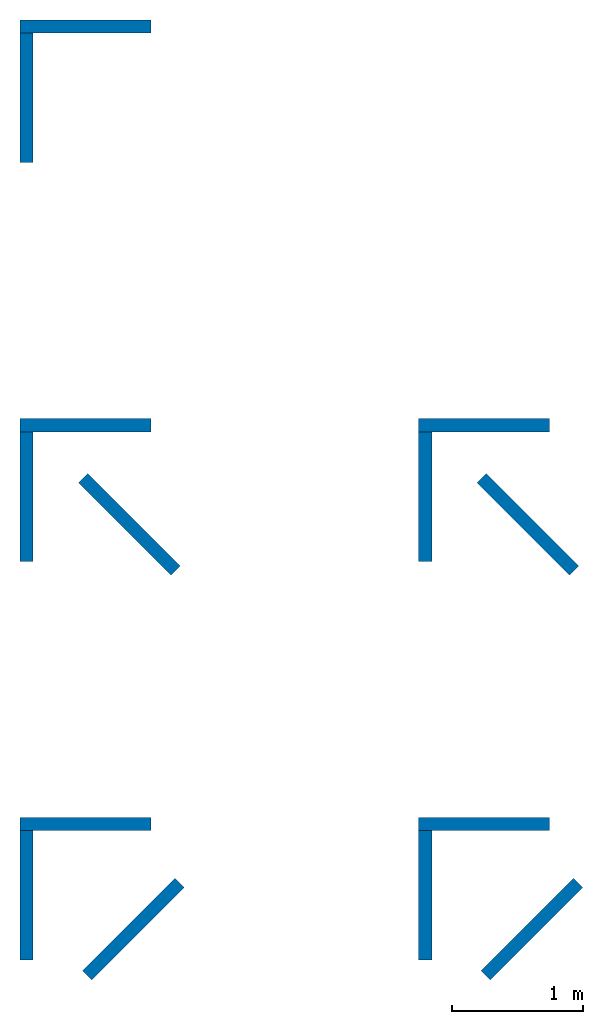
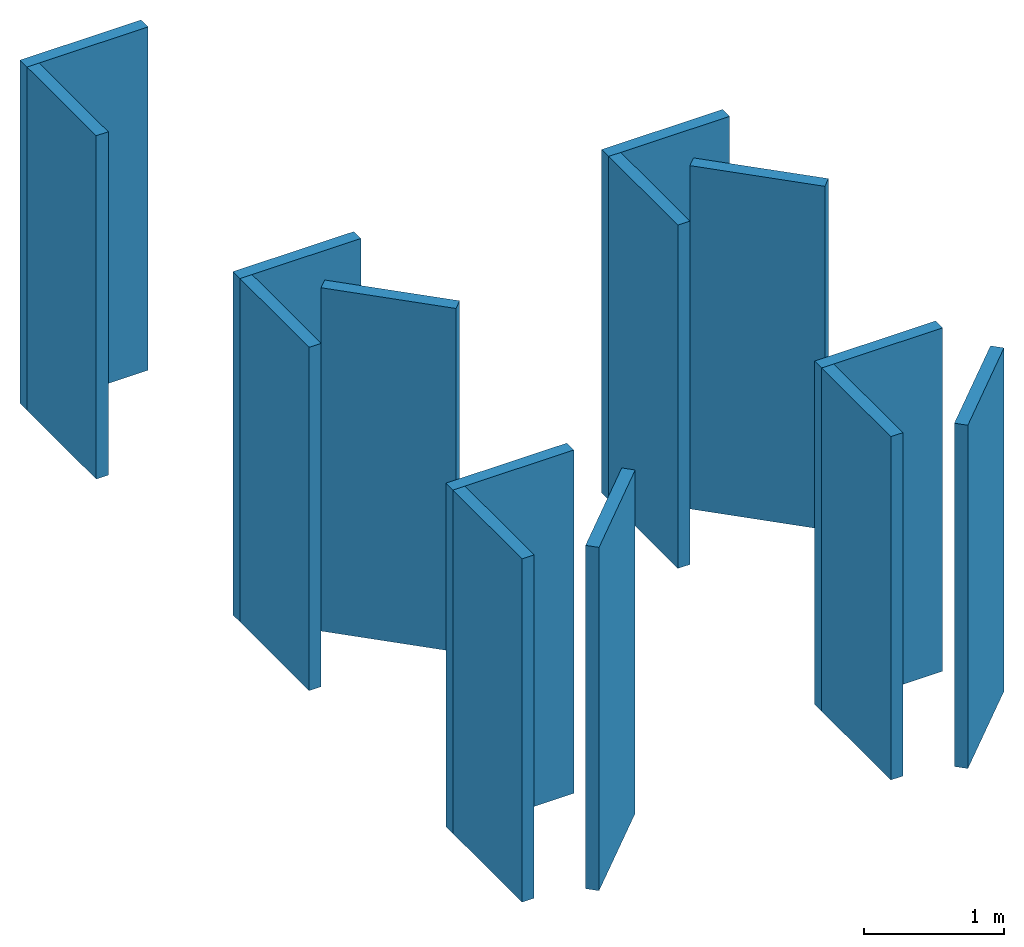
# One storey: 14 walls, 9 elements without a shape of their own.
"""IFC4 building model written with IfcOpenShell, lengths in feet."""

from ifc_helpers import new_model, entity, si_unit, converted_unit, frame, origin_with_axes, origin_2d_with_axis, place, context, subcontext, project, spatial, indexed_curve, outline, extrude, material, layer, layer_set, layer_usage, type_object, element, aggregate, save


model = new_model("IFC4")

# Units and contexts
model_context = context("Model", 3, precision=1e-05, world=origin_with_axes())
plan_context = context("Plan", 2, precision=1e-05, world=origin_2d_with_axis())
body_context = subcontext(model_context, "Body", "Model", "MODEL_VIEW")
ifc_project = project(units=[converted_unit("PLANEANGLEUNIT", "degree", entity("IfcReal", 0.0174532925199433), si_unit("PLANEANGLEUNIT", "RADIAN"), dimensions=[0, 0, 0, 0, 0, 0, 0]), converted_unit("AREAUNIT", "square foot", entity("IfcReal", 0.09290304), si_unit("AREAUNIT", "SQUARE_METRE"), dimensions=[2, 0, 0, 0, 0, 0, 0]), converted_unit("LENGTHUNIT", "foot", entity("IfcReal", 0.3048), si_unit("LENGTHUNIT", "METRE"), dimensions=[1, 0, 0, 0, 0, 0, 0]), converted_unit("VOLUMEUNIT", "cubic foot", entity("IfcReal", 0.0283168467116885), si_unit("VOLUMEUNIT", "CUBIC_METRE"), dimensions=[3, 0, 0, 0, 0, 0, 0])], contexts=[model_context, plan_context])

# Site, building, storey
site_placement = place(None, origin_with_axes())
site = spatial("IfcSite", under=ifc_project, at=site_placement)
building_placement = place(site_placement, origin_with_axes())
building = spatial("IfcBuilding", under=site, at=building_placement, Name="Building")
storey_placement = place(building_placement, origin_with_axes())
storey = spatial("IfcBuildingStorey", under=building, at=storey_placement, Name="Storey")

# Assembly, walls
assembly_1_placement = place(storey_placement, origin_with_axes())
assembly_1 = element("IfcElementAssembly", 1, at=assembly_1_placement, inside=storey, Name="A")
ifc_material = material()
ifc_layer = layer(ifc_material, 0.328083989501312)
ifc_layer_set = layer_set([ifc_layer])
ifc_layer_usage_1 = layer_usage(ifc_layer_set, "AXIS2", "POSITIVE", 0.0)
wall_type = type_object("IfcWallType", Name="WAL100", PredefinedType="NOTDEFINED", material=ifc_layer_set)
wall_1_placement = place(assembly_1_placement, origin_with_axes())
wall_1 = element("IfcWall", 2, at=wall_1_placement, type_object=wall_type, material=ifc_layer_usage_1, Name="Wall", context=body_context, shape_type="SweptSolid", body=[
    extrude(outline(indexed_curve([(0.0, 0.0), (0.0, 0.328083989501312), (3.28083989501312, 0.328083989501312), (3.28083989501312, 0.0), (0.0, 0.0)], self_intersect=False)), origin_with_axes(), (0.0, 0.0, 1.0), 9.84251968503937),
])
ifc_layer_usage_2 = layer_usage(ifc_layer_set, "AXIS2", "POSITIVE", 0.0)
wall_2_placement = place(assembly_1_placement, frame((0.0, 0.0, 0.0), z_axis=(0.0, 0.0, 1.0), x_axis=(-4.37113882867379e-08, -0.999999999999999, 0.0)))
wall_2 = element("IfcWall", 3, at=wall_2_placement, type_object=wall_type, material=ifc_layer_usage_2, Name="Wall", context=body_context, shape_type="SweptSolid", body=[
    extrude(outline(indexed_curve([(0.0, 0.0), (0.0, 0.328083989501312), (3.24999992360233, 0.328083989501312), (3.24999992360233, 0.0), (0.0, 0.0)], self_intersect=False)), origin_with_axes(), (0.0, 0.0, 1.0), 9.84251968503937),
])
aggregate(assembly_1, [wall_1, wall_2])

# Assembly, wall
assembly_2_placement = place(storey_placement, origin_with_axes())
assembly_2 = element("IfcElementAssembly", 4, at=assembly_2_placement, inside=storey, Name="B")
ifc_layer_usage_3 = layer_usage(ifc_layer_set, "AXIS2", "POSITIVE", 0.0)
wall_3_placement = place(assembly_2_placement, frame((1.46177702453819, -11.2787882486979, 0.0), z_axis=(0.0, 0.0, 1.0), x_axis=(0.707106781186548, -0.707106781186548, 0.0)))
wall_3 = element("IfcWall", 5, at=wall_3_placement, type_object=wall_type, material=ifc_layer_usage_3, Name="Wall", context=body_context, shape_type="SweptSolid", body=[
    extrude(outline(indexed_curve([(0.0, 0.0), (0.0, 0.328083989501312), (3.28084067722631, 0.328083989501312), (3.28084067722631, 0.0), (0.0, 0.0)], self_intersect=False)), origin_with_axes(), (0.0, 0.0, 1.0), 9.84251968503937),
])

assembly_3_placement = place(storey_placement, origin_with_axes())
assembly_3 = element("IfcElementAssembly", 6, at=assembly_3_placement, inside=storey, Name="C")
ifc_layer_usage_4 = layer_usage(ifc_layer_set, "AXIS2", "POSITIVE", 0.0)
wall_4_placement = place(assembly_3_placement, frame((1.79947283011409, -23.7494081336995, 0.0), z_axis=(0.0, 0.0, 1.0), x_axis=(0.707106721581899, 0.707106840791191, 0.0)))
wall_4 = element("IfcWall", 7, at=wall_4_placement, type_object=wall_type, material=ifc_layer_usage_4, Name="Wall", context=body_context, shape_type="SweptSolid", body=[
    extrude(outline(indexed_curve([(0.0, 0.0), (0.0, 0.328083989501312), (3.28084067722631, 0.328083989501312), (3.28084067722631, 0.0), (0.0, 0.0)], self_intersect=False)), origin_with_axes(), (0.0, 0.0, 1.0), 9.84251968503937),
])

# Assembly
assembly_4_placement = place(assembly_2_placement, frame((0.0, -10.000000319143, 0.0), z_axis=(0.0, 0.0, 1.0), x_axis=(1.0, 0.0, 0.0)))
assembly_4 = element("IfcElementAssembly", 8, at=assembly_4_placement, Name="A")

aggregate(assembly_2, [assembly_4, wall_3])

# Wall
ifc_layer_usage_5 = layer_usage(ifc_layer_set, "AXIS2", "POSITIVE", 0.0)
wall_5_placement = place(assembly_4_placement, frame((0.0, 2.03977983526932e-14, 0.0), z_axis=(0.0, 0.0, 1.0), x_axis=(3.13916473260163e-07, -0.999999999999951, 0.0)))
wall_5 = element("IfcWall", 9, at=wall_5_placement, type_object=wall_type, material=ifc_layer_usage_5, Name="Wall", context=body_context, shape_type="SweptSolid", body=[
    extrude(outline(indexed_curve([(0.0, 0.0), (0.0, 0.328083989501312), (3.24999992360233, 0.328083989501312), (3.24999992360233, 0.0), (0.0, 0.0)], self_intersect=False)), origin_with_axes(), (0.0, 0.0, 1.0), 9.84251968503937),
])

ifc_layer_usage_6 = layer_usage(ifc_layer_set, "AXIS2", "POSITIVE", 0.0)
wall_6_placement = place(assembly_4_placement, frame((0.0, 2.03977983526932e-14, 0.0), z_axis=(0.0, 0.0, 1.0), x_axis=(1.0, 0.0, 0.0)))
wall_6 = element("IfcWall", 10, at=wall_6_placement, type_object=wall_type, material=ifc_layer_usage_6, Name="Wall", context=body_context, shape_type="SweptSolid", body=[
    extrude(outline(indexed_curve([(0.0, 0.0), (0.0, 0.328083989501312), (3.28083989501312, 0.328083989501312), (3.28083989501312, 0.0), (0.0, 0.0)], self_intersect=False)), origin_with_axes(), (0.0, 0.0, 1.0), 9.84251968503937),
])

aggregate(assembly_4, [wall_5, wall_6])

# Assembly
assembly_5_placement = place(assembly_3_placement, frame((0.0, -20.000000638286, 0.0), z_axis=(0.0, 0.0, 1.0), x_axis=(1.0, 0.0, 0.0)))
assembly_5 = element("IfcElementAssembly", 11, at=assembly_5_placement, Name="A")

aggregate(assembly_3, [assembly_5, wall_4])

# Wall
ifc_layer_usage_7 = layer_usage(ifc_layer_set, "AXIS2", "POSITIVE", 0.0)
wall_7_placement = place(assembly_5_placement, frame((0.0, 4.07955967053863e-14, 0.0), z_axis=(0.0, 0.0, 1.0), x_axis=(3.13916473260163e-07, -0.999999999999951, 0.0)))
wall_7 = element("IfcWall", 12, at=wall_7_placement, type_object=wall_type, material=ifc_layer_usage_7, Name="Wall", context=body_context, shape_type="SweptSolid", body=[
    extrude(outline(indexed_curve([(0.0, 0.0), (0.0, 0.328083989501312), (3.24999992360233, 0.328083989501312), (3.24999992360233, 0.0), (0.0, 0.0)], self_intersect=False)), origin_with_axes(), (0.0, 0.0, 1.0), 9.84251968503937),
])

ifc_layer_usage_8 = layer_usage(ifc_layer_set, "AXIS2", "POSITIVE", 0.0)
wall_8_placement = place(assembly_5_placement, frame((0.0, 4.07955967053863e-14, 0.0), z_axis=(0.0, 0.0, 1.0), x_axis=(1.0, 0.0, 0.0)))
wall_8 = element("IfcWall", 13, at=wall_8_placement, type_object=wall_type, material=ifc_layer_usage_8, Name="Wall", context=body_context, shape_type="SweptSolid", body=[
    extrude(outline(indexed_curve([(0.0, 0.0), (0.0, 0.328083989501312), (3.28083989501312, 0.328083989501312), (3.28083989501312, 0.0), (0.0, 0.0)], self_intersect=False)), origin_with_axes(), (0.0, 0.0, 1.0), 9.84251968503937),
])

aggregate(assembly_5, [wall_7, wall_8])

# Assemblies, walls
assembly_6_placement = place(storey_placement, frame((10.000000319143, 0.0, 0.0), z_axis=(0.0, 0.0, 1.0), x_axis=(1.0, 0.0, 0.0)))
assembly_6 = element("IfcElementAssembly", 14, at=assembly_6_placement, inside=storey, Name="B")
ifc_layer_usage_9 = layer_usage(ifc_layer_set, "AXIS2", "POSITIVE", 0.0)
wall_9_placement = place(assembly_6_placement, frame((1.46177731786813, -11.2787882486979, 0.0), z_axis=(0.0, 0.0, 1.0), x_axis=(0.707106781186547, -0.707106781186547, 0.0)))
wall_9 = element("IfcWall", 15, at=wall_9_placement, type_object=wall_type, material=ifc_layer_usage_9, Name="Wall", context=body_context, shape_type="SweptSolid", body=[
    extrude(outline(indexed_curve([(0.0, 0.0), (0.0, 0.328083989501312), (3.28084067722631, 0.328083989501312), (3.28084067722631, 0.0), (0.0, 0.0)], self_intersect=False)), origin_with_axes(), (0.0, 0.0, 1.0), 9.84251968503937),
])
assembly_7_placement = place(assembly_6_placement, frame((0.0, -10.000000319143, 0.0), z_axis=(0.0, 0.0, 1.0), x_axis=(1.0, 0.0, 0.0)))
assembly_7 = element("IfcElementAssembly", 16, at=assembly_7_placement, Name="A")
aggregate(assembly_6, [wall_9, assembly_7])
ifc_layer_usage_10 = layer_usage(ifc_layer_set, "AXIS2", "POSITIVE", 0.0)
wall_10_placement = place(assembly_7_placement, frame((0.0, 0.0, 0.0), z_axis=(0.0, 0.0, 1.0), x_axis=(3.13916473260163e-07, -0.999999999999951, 0.0)))
wall_10 = element("IfcWall", 17, at=wall_10_placement, type_object=wall_type, material=ifc_layer_usage_10, Name="Wall", context=body_context, shape_type="SweptSolid", body=[
    extrude(outline(indexed_curve([(0.0, 0.0), (0.0, 0.328083989501312), (3.24999992360233, 0.328083989501312), (3.24999992360233, 0.0), (0.0, 0.0)], self_intersect=False)), origin_with_axes(), (0.0, 0.0, 1.0), 9.84251968503937),
])
ifc_layer_usage_11 = layer_usage(ifc_layer_set, "AXIS2", "POSITIVE", 0.0)
wall_11_placement = place(assembly_7_placement, origin_with_axes())
wall_11 = element("IfcWall", 18, at=wall_11_placement, type_object=wall_type, material=ifc_layer_usage_11, Name="Wall", context=body_context, shape_type="SweptSolid", body=[
    extrude(outline(indexed_curve([(0.0, 0.0), (0.0, 0.328083989501312), (3.28083989501312, 0.328083989501312), (3.28083989501312, 0.0), (0.0, 0.0)], self_intersect=False)), origin_with_axes(), (0.0, 0.0, 1.0), 9.84251968503937),
])
aggregate(assembly_7, [wall_10, wall_11])

assembly_8_placement = place(storey_placement, frame((10.000000319143, 0.0, 0.0), z_axis=(0.0, 0.0, 1.0), x_axis=(1.0, 0.0, 0.0)))
assembly_8 = element("IfcElementAssembly", 19, at=assembly_8_placement, inside=storey, Name="C")
ifc_layer_usage_12 = layer_usage(ifc_layer_set, "AXIS2", "POSITIVE", 0.0)
wall_12_placement = place(assembly_8_placement, frame((1.79947283011409, -23.7494081336995, 0.0), z_axis=(0.0, 0.0, 1.0), x_axis=(0.707106721581899, 0.707106840791191, 0.0)))
wall_12 = element("IfcWall", 20, at=wall_12_placement, type_object=wall_type, material=ifc_layer_usage_12, Name="Wall", context=body_context, shape_type="SweptSolid", body=[
    extrude(outline(indexed_curve([(0.0, 0.0), (0.0, 0.328083989501312), (3.28084067722631, 0.328083989501312), (3.28084067722631, 0.0), (0.0, 0.0)], self_intersect=False)), origin_with_axes(), (0.0, 0.0, 1.0), 9.84251968503937),
])
assembly_9_placement = place(assembly_8_placement, frame((0.0, -20.000000638286, 0.0), z_axis=(0.0, 0.0, 1.0), x_axis=(1.0, 0.0, 0.0)))
assembly_9 = element("IfcElementAssembly", 21, at=assembly_9_placement, Name="A")
aggregate(assembly_8, [wall_12, assembly_9])
ifc_layer_usage_13 = layer_usage(ifc_layer_set, "AXIS2", "POSITIVE", 0.0)
wall_13_placement = place(assembly_9_placement, frame((0.0, 0.0, 0.0), z_axis=(0.0, 0.0, 1.0), x_axis=(3.13916473260163e-07, -0.999999999999951, 0.0)))
wall_13 = element("IfcWall", 22, at=wall_13_placement, type_object=wall_type, material=ifc_layer_usage_13, Name="Wall", context=body_context, shape_type="SweptSolid", body=[
    extrude(outline(indexed_curve([(0.0, 0.0), (0.0, 0.328083989501312), (3.24999992360233, 0.328083989501312), (3.24999992360233, 0.0), (0.0, 0.0)], self_intersect=False)), origin_with_axes(), (0.0, 0.0, 1.0), 9.84251968503937),
])
ifc_layer_usage_14 = layer_usage(ifc_layer_set, "AXIS2", "POSITIVE", 0.0)
wall_14_placement = place(assembly_9_placement, origin_with_axes())
wall_14 = element("IfcWall", 23, at=wall_14_placement, type_object=wall_type, material=ifc_layer_usage_14, Name="Wall", context=body_context, shape_type="SweptSolid", body=[
    extrude(outline(indexed_curve([(0.0, 0.0), (0.0, 0.328083989501312), (3.28083989501312, 0.328083989501312), (3.28083989501312, 0.0), (0.0, 0.0)], self_intersect=False)), origin_with_axes(), (0.0, 0.0, 1.0), 9.84251968503937),
])
aggregate(assembly_9, [wall_13, wall_14])

save(model, "model.ifc")
